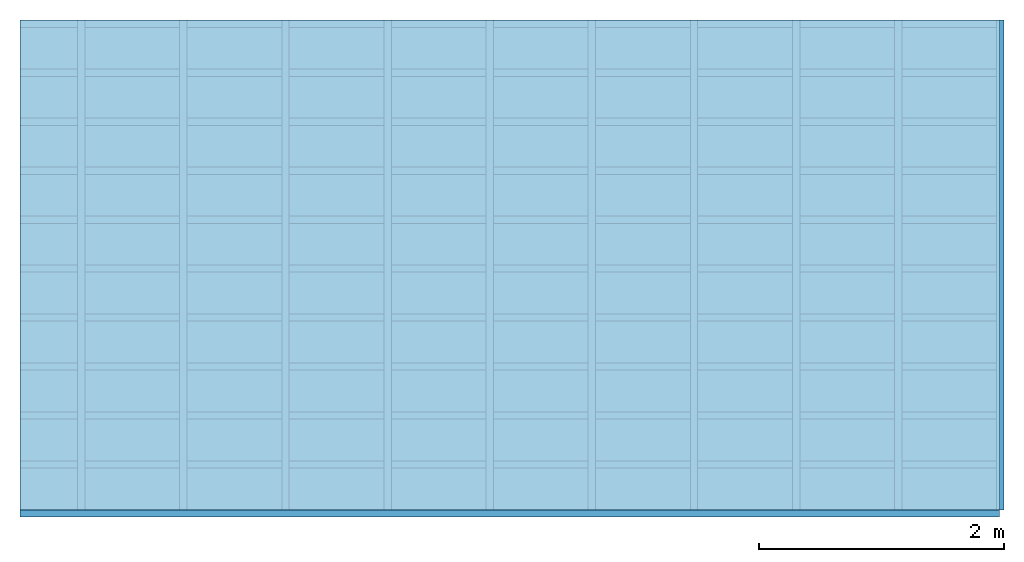
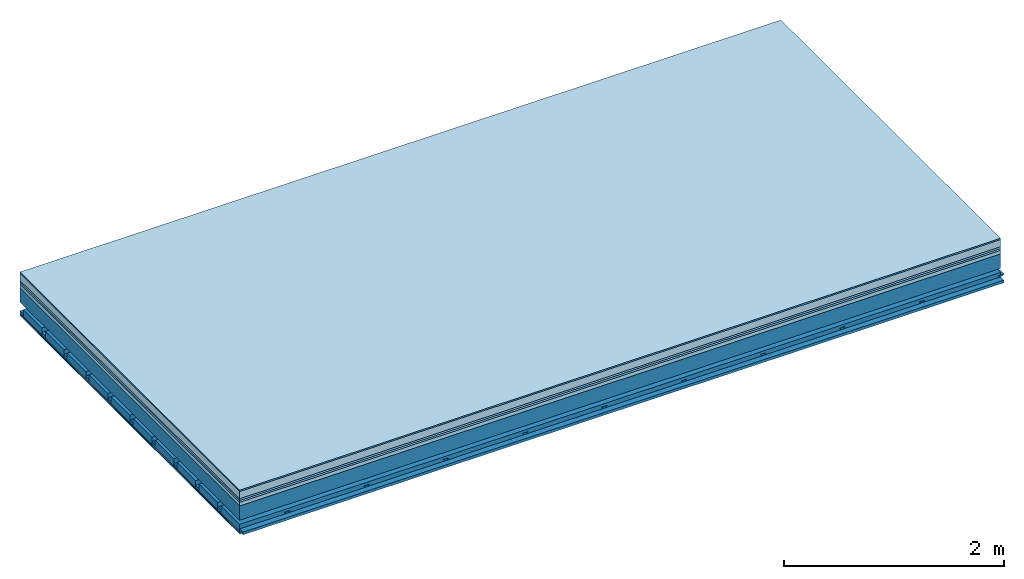
# One storey: 8 plates, 4 members, 1 element without a shape of its own.
"""IFC4 building model written with IfcOpenShell, lengths in metres."""

from ifc_helpers import new_model, si_unit, derived_unit, direction, frame, frame_2d, origin, origin_with_axes, place, context, project, spatial, polyline, rectangle, outline, extrude, material, layer, layer_set, type_object, element, aggregate, save


model = new_model("IFC4")

# Units and contexts
plan_context = context("Plan", 3, precision=1e-05, world=origin(), true_north=direction((0.0, 1.0)))
model_context = context("Model", 3, precision=1e-05, world=origin(), true_north=direction((0.0, 1.0)))
ifc_project = project(units=[si_unit("LENGTHUNIT", "METRE"), derived_unit("SOUNDPRESSUREUNIT", [(si_unit("PRESSUREUNIT", "PASCAL", prefix="MICRO"), 0)]), si_unit("ENERGYUNIT", "JOULE", prefix="MEGA"), si_unit("MASSUNIT", "GRAM", prefix="KILO"), derived_unit("THERMALTRANSMITTANCEUNIT", [(si_unit("POWERUNIT", "WATT"), 1), (si_unit("AREAUNIT", "SQUARE_METRE"), -1), (si_unit("THERMODYNAMICTEMPERATUREUNIT", "KELVIN"), -1)]), derived_unit("AREADENSITYUNIT", [(si_unit("MASSUNIT", "GRAM", prefix="KILO"), 1), (si_unit("AREAUNIT", "SQUARE_METRE"), -1)]), derived_unit("USERDEFINED", [(si_unit("ENERGYUNIT", "JOULE", prefix="MEGA"), 1), (si_unit("AREAUNIT", "SQUARE_METRE"), -1)])], contexts=[plan_context, model_context])

# Site, building, storey
site = spatial("IfcSite", under=ifc_project)
building_placement = place(None, origin())
building = spatial("IfcBuilding", under=site, at=building_placement)
storey_placement = place(building_placement, origin())
storey = spatial("IfcBuildingStorey", under=building, at=storey_placement)

# Slab, members, plates
ifc_material_1 = material(Category="11.013")
ifc_layer_1 = layer(ifc_material_1, 0.015, Name="Flooring")
ifc_material_2 = material(Name="Cement screed", Category="04.006")
ifc_layer_2 = layer(ifc_material_2, 0.08, Name="On-material")
ifc_material_3 = material(Name="Wood fiber generic product", Category="10.009")
ifc_layer_3 = layer(ifc_material_3, 0.02, Name="Impact sound insulation")
ifc_material_4 = material(Category="10.004")
ifc_layer_4 = layer(ifc_material_4, 0.02, Name="Additional insulation")
ifc_material_5 = material(Name="Garden plates", Category="02.007")
ifc_layer_5 = layer(ifc_material_5, 0.04, Name="on Supporting structure")
ifc_material_6 = material(Name="no composite action")
ifc_layer_6 = layer(ifc_material_6, 0.0, Name="Bond")
ifc_layer_7 = layer(None, 0.16, Name="Supporting structure")
ifc_layer_8 = layer(ifc_material_6, 0.0, Name="Bond")
ifc_layer_9 = layer(None, 0.095, Name="Coupling")
ifc_layer_10 = layer(None, 0.03, Name="Battens / profiles")
ifc_material_7 = material(Name="Plasterboard type A", Category="03.008")
ifc_layer_11 = layer(ifc_material_7, 0.0125, Name="Ceiling covering 1st layer")
ifc_layer_12 = layer(ifc_material_7, 0.0125, Name="Ceiling covering layer 2")
ifc_material_8 = material(Category="04.001")
ifc_layer_13 = layer(ifc_material_8, 0.003, Name="Surface / treatment")
ifc_layer_set = layer_set([ifc_layer_1, ifc_layer_2, ifc_layer_3, ifc_layer_4, ifc_layer_5, ifc_layer_6, ifc_layer_7, ifc_layer_8, ifc_layer_9, ifc_layer_10, ifc_layer_11, ifc_layer_12, ifc_layer_13])
slab_type = type_object("IfcSlabType", Name="A2170", PredefinedType="NOTDEFINED", material=ifc_layer_set)
slab_placement = place(None, frame((0.0, 0.0, 0.0), z_axis=(0.0, 0.0, -1.0), x_axis=(1.0, 0.0, 0.0)))
slab = element("IfcSlab", 1, at=slab_placement, inside=storey, type_object=slab_type, material=ifc_layer_set, Name="Slab #1")
ifc_material_9 = material(Name="Solid timber panel")
member_1_placement = place(slab_placement, origin())
member_1 = element("IfcMember", 2, at=member_1_placement, material=ifc_material_9, Name="Supporting structure", context=plan_context, shape_type="SweptSolid", body=[
    extrude(rectangle(XDim=1.0, YDim=0.16, at=frame_2d((0.5, 0.08), x_axis=(1.0, 0.0))), frame((0.0, 4.0, 0.175), z_axis=(0.0, -1.0, 0.0), x_axis=(1.0, 0.0, 0.0)), (0.0, 0.0, 1.0), 4.0),
    extrude(rectangle(XDim=1.0, YDim=0.16, at=frame_2d((0.5, 0.08), x_axis=(1.0, 0.0))), frame((1.0, 4.0, 0.175), z_axis=(0.0, -1.0, 0.0), x_axis=(1.0, 0.0, 0.0)), (0.0, 0.0, 1.0), 4.0),
    extrude(rectangle(XDim=1.0, YDim=0.16, at=frame_2d((0.5, 0.08), x_axis=(1.0, 0.0))), frame((2.0, 4.0, 0.175), z_axis=(0.0, -1.0, 0.0), x_axis=(1.0, 0.0, 0.0)), (0.0, 0.0, 1.0), 4.0),
    extrude(rectangle(XDim=1.0, YDim=0.16, at=frame_2d((0.5, 0.08), x_axis=(1.0, 0.0))), frame((3.0, 4.0, 0.175), z_axis=(0.0, -1.0, 0.0), x_axis=(1.0, 0.0, 0.0)), (0.0, 0.0, 1.0), 4.0),
    extrude(rectangle(XDim=1.0, YDim=0.16, at=frame_2d((0.5, 0.08), x_axis=(1.0, 0.0))), frame((4.0, 4.0, 0.175), z_axis=(0.0, -1.0, 0.0), x_axis=(1.0, 0.0, 0.0)), (0.0, 0.0, 1.0), 4.0),
    extrude(rectangle(XDim=1.0, YDim=0.16, at=frame_2d((0.5, 0.08), x_axis=(1.0, 0.0))), frame((5.0, 4.0, 0.175), z_axis=(0.0, -1.0, 0.0), x_axis=(1.0, 0.0, 0.0)), (0.0, 0.0, 1.0), 4.0),
    extrude(rectangle(XDim=1.0, YDim=0.16, at=frame_2d((0.5, 0.08), x_axis=(1.0, 0.0))), frame((6.0, 4.0, 0.175), z_axis=(0.0, -1.0, 0.0), x_axis=(1.0, 0.0, 0.0)), (0.0, 0.0, 1.0), 4.0),
    extrude(rectangle(XDim=1.0, YDim=0.16, at=frame_2d((0.5, 0.08), x_axis=(1.0, 0.0))), frame((7.0, 4.0, 0.175), z_axis=(0.0, -1.0, 0.0), x_axis=(1.0, 0.0, 0.0)), (0.0, 0.0, 1.0), 4.0),
])
ifc_material_10 = material()
member_2_placement = place(slab_placement, origin())
member_2 = element("IfcMember", 3, at=member_2_placement, material=ifc_material_10, Name="Coupling", context=plan_context, shape_type="SweptSolid", body=[
    extrude(outline(polyline([(0.0, 0.0), (0.06, 0.0), (0.04, 0.02), (0.02, 0.02), (0.0, 0.0)])), frame((0.47, 4.0, 0.41), z_axis=(0.0, -1.0, 0.0), x_axis=(1.0, 0.0, 0.0)), (0.0, 0.0, 1.0), 4.0),
    extrude(outline(polyline([(0.0, 0.0), (0.06, 0.0), (0.04, 0.02), (0.02, 0.02), (0.0, 0.0)])), frame((1.304, 4.0, 0.41), z_axis=(0.0, -1.0, 0.0), x_axis=(1.0, 0.0, 0.0)), (0.0, 0.0, 1.0), 4.0),
    extrude(outline(polyline([(0.0, 0.0), (0.06, 0.0), (0.04, 0.02), (0.02, 0.02), (0.0, 0.0)])), frame((2.138, 4.0, 0.41), z_axis=(0.0, -1.0, 0.0), x_axis=(1.0, 0.0, 0.0)), (0.0, 0.0, 1.0), 4.0),
    extrude(outline(polyline([(0.0, 0.0), (0.06, 0.0), (0.04, 0.02), (0.02, 0.02), (0.0, 0.0)])), frame((2.972, 4.0, 0.41), z_axis=(0.0, -1.0, 0.0), x_axis=(1.0, 0.0, 0.0)), (0.0, 0.0, 1.0), 4.0),
    extrude(outline(polyline([(0.0, 0.0), (0.06, 0.0), (0.04, 0.02), (0.02, 0.02), (0.0, 0.0)])), frame((3.806, 4.0, 0.41), z_axis=(0.0, -1.0, 0.0), x_axis=(1.0, 0.0, 0.0)), (0.0, 0.0, 1.0), 4.0),
    extrude(outline(polyline([(0.0, 0.0), (0.06, 0.0), (0.04, 0.02), (0.02, 0.02), (0.0, 0.0)])), frame((4.64, 4.0, 0.41), z_axis=(0.0, -1.0, 0.0), x_axis=(1.0, 0.0, 0.0)), (0.0, 0.0, 1.0), 4.0),
    extrude(outline(polyline([(0.0, 0.0), (0.06, 0.0), (0.04, 0.02), (0.02, 0.02), (0.0, 0.0)])), frame((5.474, 4.0, 0.41), z_axis=(0.0, -1.0, 0.0), x_axis=(1.0, 0.0, 0.0)), (0.0, 0.0, 1.0), 4.0),
    extrude(outline(polyline([(0.0, 0.0), (0.06, 0.0), (0.04, 0.02), (0.02, 0.02), (0.0, 0.0)])), frame((6.308, 4.0, 0.41), z_axis=(0.0, -1.0, 0.0), x_axis=(1.0, 0.0, 0.0)), (0.0, 0.0, 1.0), 4.0),
    extrude(outline(polyline([(0.0, 0.0), (0.06, 0.0), (0.04, 0.02), (0.02, 0.02), (0.0, 0.0)])), frame((7.142, 4.0, 0.41), z_axis=(0.0, -1.0, 0.0), x_axis=(1.0, 0.0, 0.0)), (0.0, 0.0, 1.0), 4.0),
    extrude(outline(polyline([(0.0, 0.0), (0.06, 0.0), (0.04, 0.02), (0.02, 0.02), (0.0, 0.0)])), frame((7.976, 4.0, 0.41), z_axis=(0.0, -1.0, 0.0), x_axis=(1.0, 0.0, 0.0)), (0.0, 0.0, 1.0), 4.0),
])
member_3_placement = place(slab_placement, origin())
member_3 = element("IfcMember", 4, at=member_3_placement, material=ifc_material_10, Name="Battens / profiles", context=plan_context, shape_type="SweptSolid", body=[
    extrude(rectangle(XDim=0.06, YDim=0.03, at=frame_2d((0.03, 0.015), x_axis=(1.0, 0.0))), frame((0.0, 0.0, 0.43), z_axis=(1.0, 0.0, 0.0), x_axis=(0.0, 1.0, 0.0)), (0.0, 0.0, 1.0), 8.0),
    extrude(rectangle(XDim=0.06, YDim=0.03, at=frame_2d((0.03, 0.015), x_axis=(1.0, 0.0))), frame((0.0, 0.4, 0.43), z_axis=(1.0, 0.0, 0.0), x_axis=(0.0, 1.0, 0.0)), (0.0, 0.0, 1.0), 8.0),
    extrude(rectangle(XDim=0.06, YDim=0.03, at=frame_2d((0.03, 0.015), x_axis=(1.0, 0.0))), frame((0.0, 0.8, 0.43), z_axis=(1.0, 0.0, 0.0), x_axis=(0.0, 1.0, 0.0)), (0.0, 0.0, 1.0), 8.0),
    extrude(rectangle(XDim=0.06, YDim=0.03, at=frame_2d((0.03, 0.015), x_axis=(1.0, 0.0))), frame((0.0, 1.2, 0.43), z_axis=(1.0, 0.0, 0.0), x_axis=(0.0, 1.0, 0.0)), (0.0, 0.0, 1.0), 8.0),
    extrude(rectangle(XDim=0.06, YDim=0.03, at=frame_2d((0.03, 0.015), x_axis=(1.0, 0.0))), frame((0.0, 1.6, 0.43), z_axis=(1.0, 0.0, 0.0), x_axis=(0.0, 1.0, 0.0)), (0.0, 0.0, 1.0), 8.0),
    extrude(rectangle(XDim=0.06, YDim=0.03, at=frame_2d((0.03, 0.015), x_axis=(1.0, 0.0))), frame((0.0, 2.0, 0.43), z_axis=(1.0, 0.0, 0.0), x_axis=(0.0, 1.0, 0.0)), (0.0, 0.0, 1.0), 8.0),
    extrude(rectangle(XDim=0.06, YDim=0.03, at=frame_2d((0.03, 0.015), x_axis=(1.0, 0.0))), frame((0.0, 2.4, 0.43), z_axis=(1.0, 0.0, 0.0), x_axis=(0.0, 1.0, 0.0)), (0.0, 0.0, 1.0), 8.0),
    extrude(rectangle(XDim=0.06, YDim=0.03, at=frame_2d((0.03, 0.015), x_axis=(1.0, 0.0))), frame((0.0, 2.8, 0.43), z_axis=(1.0, 0.0, 0.0), x_axis=(0.0, 1.0, 0.0)), (0.0, 0.0, 1.0), 8.0),
    extrude(rectangle(XDim=0.06, YDim=0.03, at=frame_2d((0.03, 0.015), x_axis=(1.0, 0.0))), frame((0.0, 3.2, 0.43), z_axis=(1.0, 0.0, 0.0), x_axis=(0.0, 1.0, 0.0)), (0.0, 0.0, 1.0), 8.0),
    extrude(rectangle(XDim=0.06, YDim=0.03, at=frame_2d((0.03, 0.015), x_axis=(1.0, 0.0))), frame((0.0, 3.6, 0.43), z_axis=(1.0, 0.0, 0.0), x_axis=(0.0, 1.0, 0.0)), (0.0, 0.0, 1.0), 8.0),
    extrude(rectangle(XDim=0.06, YDim=0.03, at=frame_2d((0.03, 0.015), x_axis=(1.0, 0.0))), frame((0.0, 4.0, 0.43), z_axis=(1.0, 0.0, 0.0), x_axis=(0.0, 1.0, 0.0)), (0.0, 0.0, 1.0), 8.0),
])
ifc_material_11 = material()
member_4_placement = place(slab_placement, origin())
member_4 = element("IfcMember", 5, at=member_4_placement, material=ifc_material_11, Name="Cavity", context=plan_context, shape_type="SweptSolid", body=[
    extrude(rectangle(XDim=0.34, YDim=0.08, at=frame_2d((0.17, 0.04), x_axis=(1.0, 0.0))), frame((0.0, 0.06, 0.38), z_axis=(1.0, 0.0, 0.0), x_axis=(0.0, 1.0, 0.0)), (0.0, 0.0, 1.0), 8.0),
    extrude(rectangle(XDim=0.34, YDim=0.08, at=frame_2d((0.17, 0.04), x_axis=(1.0, 0.0))), frame((0.0, 0.46, 0.38), z_axis=(1.0, 0.0, 0.0), x_axis=(0.0, 1.0, 0.0)), (0.0, 0.0, 1.0), 8.0),
    extrude(rectangle(XDim=0.34, YDim=0.08, at=frame_2d((0.17, 0.04), x_axis=(1.0, 0.0))), frame((0.0, 0.86, 0.38), z_axis=(1.0, 0.0, 0.0), x_axis=(0.0, 1.0, 0.0)), (0.0, 0.0, 1.0), 8.0),
    extrude(rectangle(XDim=0.34, YDim=0.08, at=frame_2d((0.17, 0.04), x_axis=(1.0, 0.0))), frame((0.0, 1.26, 0.38), z_axis=(1.0, 0.0, 0.0), x_axis=(0.0, 1.0, 0.0)), (0.0, 0.0, 1.0), 8.0),
    extrude(rectangle(XDim=0.34, YDim=0.08, at=frame_2d((0.17, 0.04), x_axis=(1.0, 0.0))), frame((0.0, 1.66, 0.38), z_axis=(1.0, 0.0, 0.0), x_axis=(0.0, 1.0, 0.0)), (0.0, 0.0, 1.0), 8.0),
    extrude(rectangle(XDim=0.34, YDim=0.08, at=frame_2d((0.17, 0.04), x_axis=(1.0, 0.0))), frame((0.0, 2.06, 0.38), z_axis=(1.0, 0.0, 0.0), x_axis=(0.0, 1.0, 0.0)), (0.0, 0.0, 1.0), 8.0),
    extrude(rectangle(XDim=0.34, YDim=0.08, at=frame_2d((0.17, 0.04), x_axis=(1.0, 0.0))), frame((0.0, 2.46, 0.38), z_axis=(1.0, 0.0, 0.0), x_axis=(0.0, 1.0, 0.0)), (0.0, 0.0, 1.0), 8.0),
    extrude(rectangle(XDim=0.34, YDim=0.08, at=frame_2d((0.17, 0.04), x_axis=(1.0, 0.0))), frame((0.0, 2.86, 0.38), z_axis=(1.0, 0.0, 0.0), x_axis=(0.0, 1.0, 0.0)), (0.0, 0.0, 1.0), 8.0),
    extrude(rectangle(XDim=0.34, YDim=0.08, at=frame_2d((0.17, 0.04), x_axis=(1.0, 0.0))), frame((0.0, 3.26, 0.38), z_axis=(1.0, 0.0, 0.0), x_axis=(0.0, 1.0, 0.0)), (0.0, 0.0, 1.0), 8.0),
    extrude(rectangle(XDim=0.34, YDim=0.08, at=frame_2d((0.17, 0.04), x_axis=(1.0, 0.0))), frame((0.0, 3.66, 0.38), z_axis=(1.0, 0.0, 0.0), x_axis=(0.0, 1.0, 0.0)), (0.0, 0.0, 1.0), 8.0),
])
plate_1_placement = place(slab_placement, origin())
plate_1 = element("IfcPlate", 6, at=plate_1_placement, material=ifc_material_1, Name="Flooring", context=plan_context, shape_type="SweptSolid", body=[
    extrude(rectangle(XDim=8.0, YDim=4.0, at=frame_2d((4.0, 2.0), x_axis=(1.0, 0.0))), origin_with_axes(), (0.0, 0.0, 1.0), 0.015),
])
plate_2_placement = place(slab_placement, origin())
plate_2 = element("IfcPlate", 7, at=plate_2_placement, material=ifc_material_2, Name="On-material", context=plan_context, shape_type="SweptSolid", body=[
    extrude(rectangle(XDim=8.0, YDim=4.0, at=frame_2d((4.0, 2.0), x_axis=(1.0, 0.0))), frame((0.0, 0.0, 0.015), z_axis=(0.0, 0.0, 1.0), x_axis=(1.0, 0.0, 0.0)), (0.0, 0.0, 1.0), 0.08),
])
plate_3_placement = place(slab_placement, origin())
plate_3 = element("IfcPlate", 8, at=plate_3_placement, material=ifc_material_3, Name="Impact sound insulation", context=plan_context, shape_type="SweptSolid", body=[
    extrude(rectangle(XDim=8.0, YDim=4.0, at=frame_2d((4.0, 2.0), x_axis=(1.0, 0.0))), frame((0.0, 0.0, 0.095), z_axis=(0.0, 0.0, 1.0), x_axis=(1.0, 0.0, 0.0)), (0.0, 0.0, 1.0), 0.02),
])
plate_4_placement = place(slab_placement, origin())
plate_4 = element("IfcPlate", 9, at=plate_4_placement, material=ifc_material_4, Name="Additional insulation", context=plan_context, shape_type="SweptSolid", body=[
    extrude(rectangle(XDim=8.0, YDim=4.0, at=frame_2d((4.0, 2.0), x_axis=(1.0, 0.0))), frame((0.0, 0.0, 0.115), z_axis=(0.0, 0.0, 1.0), x_axis=(1.0, 0.0, 0.0)), (0.0, 0.0, 1.0), 0.02),
])
plate_5_placement = place(slab_placement, origin())
plate_5 = element("IfcPlate", 10, at=plate_5_placement, material=ifc_material_5, Name="on Supporting structure", context=plan_context, shape_type="SweptSolid", body=[
    extrude(rectangle(XDim=8.0, YDim=4.0, at=frame_2d((4.0, 2.0), x_axis=(1.0, 0.0))), frame((0.0, 0.0, 0.135), z_axis=(0.0, 0.0, 1.0), x_axis=(1.0, 0.0, 0.0)), (0.0, 0.0, 1.0), 0.04),
])
plate_6_placement = place(slab_placement, origin())
plate_6 = element("IfcPlate", 11, at=plate_6_placement, material=ifc_material_7, Name="Ceiling covering 1st layer", context=plan_context, shape_type="SweptSolid", body=[
    extrude(rectangle(XDim=8.0, YDim=4.0, at=frame_2d((4.0, 2.0), x_axis=(1.0, 0.0))), frame((0.0, 0.0, 0.46), z_axis=(0.0, 0.0, 1.0), x_axis=(1.0, 0.0, 0.0)), (0.0, 0.0, 1.0), 0.0125),
])
plate_7_placement = place(slab_placement, origin())
plate_7 = element("IfcPlate", 12, at=plate_7_placement, material=ifc_material_7, Name="Ceiling covering layer 2", context=plan_context, shape_type="SweptSolid", body=[
    extrude(rectangle(XDim=8.0, YDim=4.0, at=frame_2d((4.0, 2.0), x_axis=(1.0, 0.0))), frame((0.0, 0.0, 0.4725), z_axis=(0.0, 0.0, 1.0), x_axis=(1.0, 0.0, 0.0)), (0.0, 0.0, 1.0), 0.0125),
])
plate_8_placement = place(slab_placement, origin())
plate_8 = element("IfcPlate", 13, at=plate_8_placement, material=ifc_material_8, Name="Surface / treatment", context=plan_context, shape_type="SweptSolid", body=[
    extrude(rectangle(XDim=8.0, YDim=4.0, at=frame_2d((4.0, 2.0), x_axis=(1.0, 0.0))), frame((0.0, 0.0, 0.485), z_axis=(0.0, 0.0, 1.0), x_axis=(1.0, 0.0, 0.0)), (0.0, 0.0, 1.0), 0.003),
])
aggregate(slab, [plate_1, plate_2, plate_3, plate_4, plate_5, member_1, member_2, member_3, member_4, plate_6, plate_7, plate_8])

save(model, "model.ifc")
